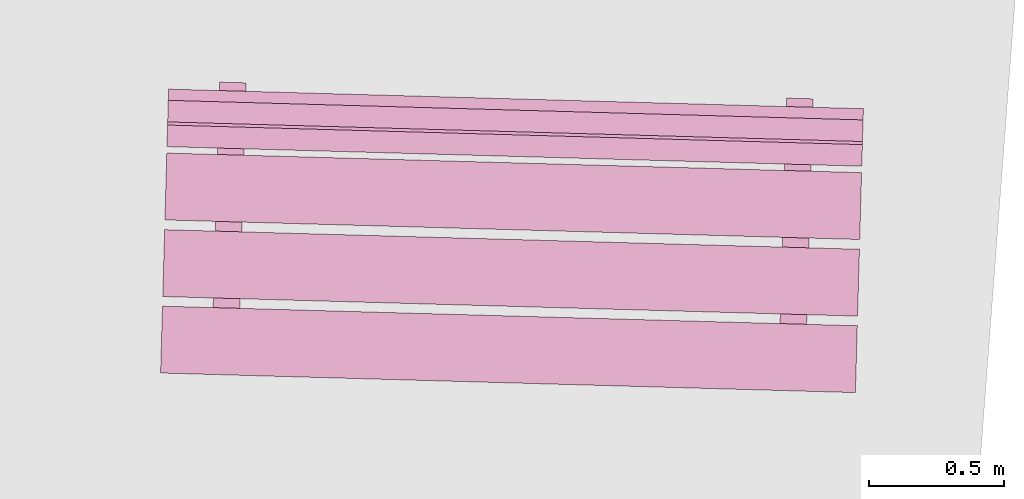
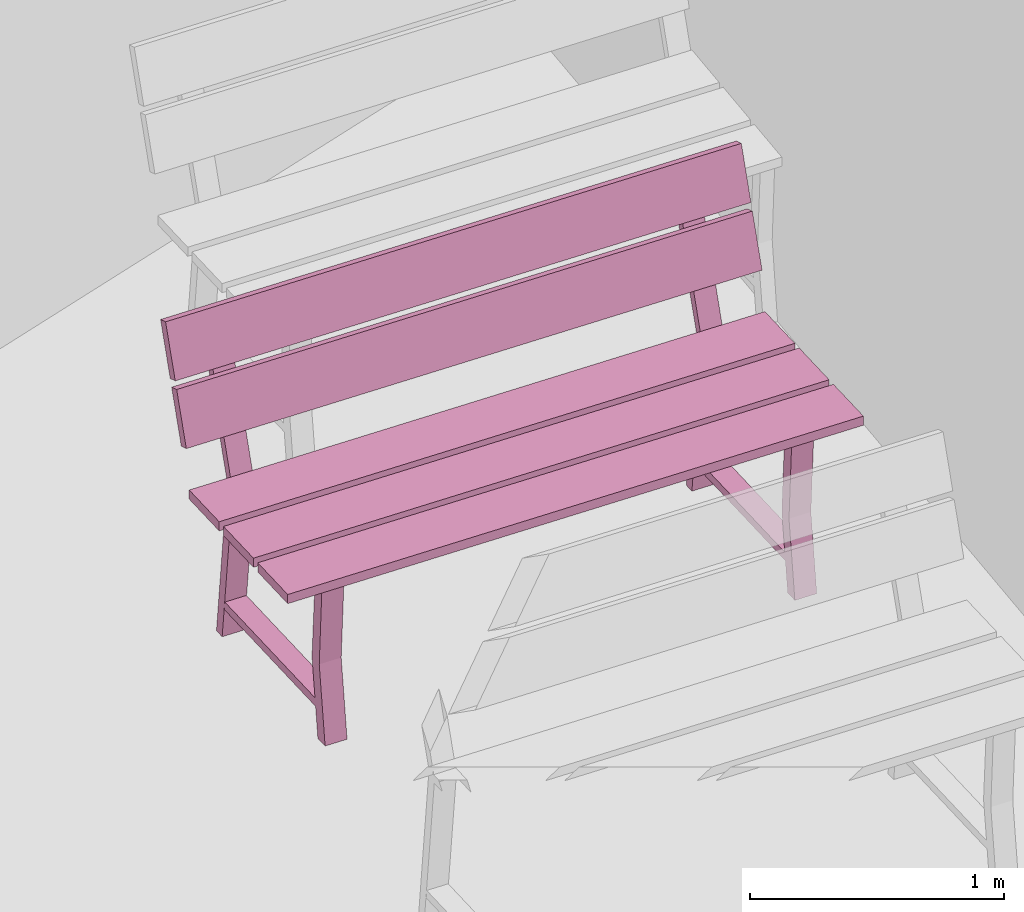
# One storey, part 19 of 200: 1 furnishing.
"""IFC4 building model written with IfcOpenShell, lengths in metres."""

from ifc_helpers import new_model, si_unit, origin_with_axes, place, context, subcontext, project, spatial, triangles, material, element, save


model = new_model("IFC4")

# Units and contexts
model_context = context("Model", 3, precision=1e-05, world=origin_with_axes())
body_context = subcontext(model_context, "Body", "Model", "MODEL_VIEW")
ifc_project = project(units=[si_unit("VOLUMEUNIT", "CUBIC_METRE"), si_unit("LENGTHUNIT", "METRE"), si_unit("AREAUNIT", "SQUARE_METRE")], contexts=[model_context])

# Site, building, storey
site_placement = place(None, origin_with_axes())
site = spatial("IfcSite", under=ifc_project, at=site_placement)
building_placement = place(site_placement, origin_with_axes())
building = spatial("IfcBuilding", under=site, at=building_placement, Name="Building")
storey_placement = place(building_placement, origin_with_axes())
storey = spatial("IfcBuildingStorey", under=building, at=storey_placement, Name="Ground")

# Furnishing
ifc_material = material(Name="bench")
furnishing_placement = place(storey_placement, origin_with_axes())
element("IfcFurnishingElement", 1, at=furnishing_placement, inside=storey, material=ifc_material, Name="cw_instances_bench_54", context=body_context, shape_type="Tessellation", body=[
    triangles([(238.3590412349621, -459.2790719184696, 0.8154595552323105), (238.36603468493595, -459.03091724197816, 0.8154595552323105), (235.7877960065481, -458.9582577883145, 0.8154595552323105), (235.78080255657426, -459.2064124648059, 0.8154595552323105), (235.96535536408615, -459.34840795630964, 0.3631407258093263), (236.0636534565917, -459.35117817528027, 0.3631407258093263), (236.06227739785223, -459.4000060660356, 1.4461350578594623e-07), (235.9639793053467, -459.39723584706496, 1.4461350578594623e-07), (236.0619650703966, -459.4110886531704, 0.3631407258093263), (235.96229544475085, -459.4569857391755, 1.606816730954958e-07), (236.0605935372564, -459.4597559581461, 1.606816730954958e-07), (235.96366697789108, -459.40831843419977, 0.3631407258093263), (236.08343428371427, -458.6492778580279, 0.7741643170422662), (236.08343428371427, -458.6492778580279, 0.7741643170422662), (236.08596459613344, -458.55949257863864, 0.0), (235.98766650362788, -458.5567223596681, 0.0), (235.98766650362788, -458.5567223596681, 0.0), (235.98465435356096, -458.6464940599963, 0.7741643170422662), (236.08223475955734, -458.69184161843526, 0.7346366254607741), (235.98634023689104, -458.6037834374265, 1.6068167309549576e-08), (236.0846383293966, -458.6065536563971, 1.6068167309549576e-08), (235.98393666705178, -458.68907139946464, 0.7352793682213234), (235.96467638976245, -459.37250059360287, 0.7352794646303272), (236.0629654292589, -459.3755920483799, 0.7346367218697779), (236.0612634644555, -459.435984347856, 0.7741644616557719), (235.96248353430215, -459.4332005498244, 0.7741644616557719), (238.35104290188468, -459.56288373734577, 0.8154596516413144), (238.35803635140587, -459.31472907691614, 0.8154595552323105), (235.77979767301804, -459.24206962325246, 0.8154595552323105), (235.77280422349682, -459.4902242836821, 0.8154596516413144), (238.36705314845844, -458.99477821376024, 0.8154595552323105), (238.37404659797966, -458.7466235533306, 0.8154594588233067), (235.7958079195918, -458.673964099667, 0.8154594588233067), (235.7888144700706, -458.9221187600966, 0.8154595552323105), (238.3747165211049, -458.7228520875966, 0.9999220838096051), (235.79873657029532, -458.57004423599363, 1.234838593466216), (235.79647784271702, -458.65019263393293, 0.9999220838096051), (238.37697524868315, -458.6427036896573, 1.234838593466216), (238.37730115746302, -458.63113918456577, 1.2690638219718915), (235.80132120574817, -458.4783313650864, 1.5039802352194984), (235.7990624790752, -458.5584797309021, 1.2690638219718915), (238.379559884136, -458.55099081875005, 1.5039802352194984), (235.99162045211648, -458.4107159494546, 1.4583467364693816), (236.08991864099278, -458.4134861711411, 1.4583467364693816), (236.08343428371427, -458.6492778580279, 0.7741643170422662), (235.98465435356096, -458.6464940599963, 0.7741643170422662), (235.9840543566226, -458.6848953179199, 0.7738429536960751), (236.08236602818914, -458.6871836992427, 0.7738429536960751), (236.08884585941573, -458.4515526141973, 1.4723259616878532), (235.99053409147845, -458.4492642301586, 1.4723259616878532), (235.79765020784671, -458.6085925809448, 0.9857820483726994), (235.79990440937308, -458.52860478484683, 1.2206986544383143), (238.37588888623455, -458.6812520346084, 0.9857820483726994), (238.37814308776095, -458.6012642385105, 1.2206986544383143), (235.8002348437522, -458.51687969397574, 1.2549238829439897), (235.80249357087783, -458.4367313120982, 1.4898404890096046), (238.37847352214004, -458.58953914763936, 1.2549238829439897), (238.38073224926566, -458.50939076576185, 1.4898404890096046), (238.06896805823652, -459.40769158678114, 0.3631407258093263), (238.16726615074208, -459.41046180575177, 0.3631407258093263), (238.1658900920026, -459.4592896965071, 1.4461350578594623e-07), (238.06759199949707, -459.45651947753646, 1.4461350578594623e-07), (238.165577764547, -459.4703722836419, 0.3631407258093263), (238.06590813890122, -459.516269369647, 1.606816730954958e-07), (238.16420623140678, -459.5190395886176, 1.606816730954958e-07), (238.06727967204145, -459.46760206467127, 0.3631407258093263), (238.18704697786464, -458.70856148849947, 0.7741643170422662), (238.18704697786464, -458.70856148849947, 0.7741643170422662), (238.1895772902838, -458.61877620911014, 0.0), (238.09127919777825, -458.61600599013957, 0.0), (238.09127919777825, -458.61600599013957, 0.0), (238.08842760136736, -458.7057822151618, 0.7741643170422662), (238.1858474537077, -458.75112524890676, 0.7346366254607741), (238.0899529310414, -458.663067067898, 1.6068167309549576e-08), (238.18825102354697, -458.6658372868686, 1.6068167309549576e-08), (238.08754936120218, -458.74835502993614, 0.7352793682213234), (238.06828908391282, -459.43178422407436, 0.7352794646303272), (238.16657812340927, -459.43487567885137, 0.7346367218697779), (238.16487615860586, -459.4952679783275, 0.7741644616557719), (238.06625678210855, -459.49248870498985, 0.7741644616557719), (238.09539379629362, -458.4700041073359, 1.4583467364693816), (238.19353135120494, -458.4727698020653, 1.4583467364693816), (238.18704697786464, -458.70856148849947, 0.7741643170422662), (238.08842760136736, -458.7057822151618, 0.7741643170422662), (238.08766705077298, -458.74417894839144, 0.7738429536960751), (238.1859787223395, -458.7464673297142, 0.7738429536960751), (238.1924585696279, -458.5108362451214, 1.4723259616878532), (238.0943074356556, -458.5085523880399, 1.4723259616878532), (238.36603468493595, -459.03091724197816, 0.8154595552323105), (235.7877960065481, -458.9582577883145, 0.7715934584772401), (235.7877960065481, -458.9582577883145, 0.8154595552323105), (238.36603468493595, -459.03091724197816, 0.7715934584772401), (238.3590412349621, -459.2790719184696, 0.771593506681742), (235.78080255657426, -459.2064124648059, 0.8154595552323105), (235.78080255657426, -459.2064124648059, 0.771593506681742), (238.3590412349621, -459.2790719184696, 0.8154595552323105), (235.9639793053467, -459.39723584706496, 1.4461350578594623e-07), (235.96366697789108, -459.40831843419977, 0.3631407258093263), (235.96535536408615, -459.34840795630964, 0.3631407258093263), (235.96229544475085, -459.4569857391755, 1.606816730954958e-07), (235.98393666705178, -458.68907139946464, 0.7352793682213234), (235.98465435356096, -458.6464940599963, 0.7741643170422662), (235.98766650362788, -458.5567223596681, 0.0), (235.98634023689104, -458.6037834374265, 1.6068167309549576e-08), (236.0619650703966, -459.4110886531704, 0.3631407258093263), (236.0636534565917, -459.35117817528027, 0.3631407258093263), (236.0629654292589, -459.3755920483799, 0.7346367218697779), (236.0612634644555, -459.435984347856, 0.7741644616557719), (236.08343428371427, -458.6492778580279, 0.7741643170422662), (236.08223475955734, -458.69184161843526, 0.7346366254607741), (236.08596459613344, -458.55949257863864, 0.0), (236.0846383293966, -458.6065536563971, 1.6068167309549576e-08), (235.96467638976245, -459.37250059360287, 0.7352794646303272), (235.96248353430215, -459.4332005498244, 0.7741644616557719), (236.06227739785223, -459.4000060660356, 1.4461350578594623e-07), (236.0605935372564, -459.4597559581461, 1.606816730954958e-07), (235.99162045211648, -458.4107159494546, 1.4583467364693816), (236.08884585941573, -458.4515526141973, 1.4723259616878532), (236.08991864099278, -458.4134861711411, 1.4583467364693816), (235.99053409147845, -458.4492642301586, 1.4723259616878532), (236.08319714966146, -458.6177651919651, 0.13995373726617685), (236.08319714966146, -458.6177651919651, 0.17948142884766885), (236.06138845121887, -459.3916222334761, 0.13995388187968263), (236.06137487125258, -459.39210410324745, 0.1794815734611746), (235.98682640774703, -458.6150492892384, 0.17948142884766885), (235.98714769173878, -458.6150583436054, 0.14059646395855885), (235.96534804585264, -459.38859416537184, 0.14059660857206463), (235.96500412933815, -459.3893882005207, 0.1794815734611746), (238.35803635140587, -459.31472907691614, 0.8154595552323105), (235.77979767301804, -459.24206962325246, 0.771593506681742), (235.77979767301804, -459.24206962325246, 0.8154595552323105), (238.35803635140587, -459.31472907691614, 0.771593506681742), (238.35104290188468, -459.56288373734577, 0.7715935548862439), (235.77280422349682, -459.4902242836821, 0.8154596516413144), (235.77280422349682, -459.4902242836821, 0.7715935548862439), (238.35104290188468, -459.56288373734577, 0.8154596516413144), (238.37404659797966, -458.7466235533306, 0.8154594588233067), (235.7958079195918, -458.673964099667, 0.7715934102727381), (235.7958079195918, -458.673964099667, 0.8154594588233067), (238.37404659797966, -458.7466235533306, 0.7715934102727381), (238.3670531480058, -458.99477822982203, 0.7715934584772401), (235.7888144700706, -458.9221187600966, 0.8154595552323105), (235.78881446961796, -458.9221187761584, 0.7715934584772401), (238.36705314845844, -458.99477821376024, 0.8154595552323105), (235.79990440937308, -458.52860478484683, 1.2206986544383143), (238.37697524868315, -458.6427036896573, 1.234838593466216), (238.37814308776095, -458.6012642385105, 1.2206986544383143), (235.79873657029532, -458.57004423599363, 1.234838593466216), (238.37588888623455, -458.6812520346084, 0.9857820483726994), (235.79647784271702, -458.65019263393293, 0.9999220838096051), (235.79765020784671, -458.6085925809448, 0.9857820483726994), (238.3747165211049, -458.7228520875966, 0.9999220838096051), (235.80249357087783, -458.4367313120982, 1.4898404890096046), (238.379559884136, -458.55099081875005, 1.5039802352194984), (238.38073224926566, -458.50939076576185, 1.4898404890096046), (235.80132120574817, -458.4783313650864, 1.5039802352194984), (238.37847352214004, -458.58953914763936, 1.2549238829439897), (235.7990624790752, -458.5584797309021, 1.2690638219718915), (235.8002348437522, -458.51687969397574, 1.2549238829439897), (238.37730115746302, -458.63113918456577, 1.2690638219718915), (238.06759199949707, -459.45651947753646, 1.4461350578594623e-07), (238.06727967204145, -459.46760206467127, 0.3631407258093263), (238.06896805823652, -459.40769158678114, 0.3631407258093263), (238.06590813890122, -459.516269369647, 1.606816730954958e-07), (238.08754936120218, -458.74835502993614, 0.7352793682213234), (238.08842760136736, -458.7057822151618, 0.7741643170422662), (238.09127919777825, -458.61600599013957, 0.0), (238.0899529310414, -458.663067067898, 1.6068167309549576e-08), (238.165577764547, -459.4703722836419, 0.3631407258093263), (238.16726615074208, -459.41046180575177, 0.3631407258093263), (238.16657812340927, -459.43487567885137, 0.7346367218697779), (238.16487615860586, -459.4952679783275, 0.7741644616557719), (238.18704697786464, -458.70856148849947, 0.7741643170422662), (238.1858474537077, -458.75112524890676, 0.7346366254607741), (238.1895772902838, -458.61877620911014, 0.0), (238.18825102354697, -458.6658372868686, 1.6068167309549576e-08), (238.06828908391282, -459.43178422407436, 0.7352794646303272), (238.06625678210855, -459.49248870498985, 0.7741644616557719), (238.1658900920026, -459.4592896965071, 1.4461350578594623e-07), (238.16420623140678, -459.5190395886176, 1.606816730954958e-07), (238.09539379629362, -458.4700041073359, 1.4583467364693816), (238.1924585696279, -458.5108362451214, 1.4723259616878532), (238.19353135120494, -458.4727698020653, 1.4583467364693816), (238.0943074356556, -458.5085523880399, 1.4723259616878532), (238.1869704938386, -458.6770533498464, 0.13995373726617685), (238.1869704938386, -458.6770533498464, 0.17948142884766885), (238.16516179539602, -459.4509103913574, 0.13995388187968263), (238.16514821542972, -459.4513922611288, 0.1794815734611746), (238.0904391018974, -458.6743329197099, 0.17948142884766885), (238.09092093954519, -458.6743464987709, 0.14059646395855885), (238.06912129365904, -459.4478823205373, 0.14059660857206463), (238.06861682348853, -459.4486718309923, 0.1794815734611746), (238.3590412349621, -459.2790719184696, 0.8154595552323105), (238.36603468493595, -459.03091724197816, 0.7715934584772401), (238.36603468493595, -459.03091724197816, 0.8154595552323105), (238.3590412349621, -459.2790719184696, 0.771593506681742), (235.7877960065481, -458.9582577883145, 0.8154595552323105), (235.7877960065481, -458.9582577883145, 0.7715934584772401), (235.78080255657426, -459.2064124648059, 0.771593506681742), (235.78080255657426, -459.2064124648059, 0.8154595552323105), (238.35104290188468, -459.56288373734577, 0.8154596516413144), (238.35803635140587, -459.31472907691614, 0.771593506681742), (238.35803635140587, -459.31472907691614, 0.8154595552323105), (238.35104290188468, -459.56288373734577, 0.7715935548862439), (235.77979767301804, -459.24206962325246, 0.8154595552323105), (235.77979767301804, -459.24206962325246, 0.771593506681742), (235.77280422349682, -459.4902242836821, 0.7715935548862439), (235.77280422349682, -459.4902242836821, 0.8154596516413144), (238.36705314845844, -458.99477821376024, 0.8154595552323105), (238.37404659797966, -458.7466235533306, 0.7715934102727381), (238.37404659797966, -458.7466235533306, 0.8154594588233067), (238.3670531480058, -458.99477822982203, 0.7715934584772401), (235.7958079195918, -458.673964099667, 0.8154594588233067), (235.7958079195918, -458.673964099667, 0.7715934102727381), (235.78881446961796, -458.9221187761584, 0.7715934584772401), (235.7888144700706, -458.9221187600966, 0.8154595552323105), (238.37588888623455, -458.6812520346084, 0.9857820483726994), (238.37814308776095, -458.6012642385105, 1.2206986544383143), (238.37697524868315, -458.6427036896573, 1.234838593466216), (238.3747165211049, -458.7228520875966, 0.9999220838096051), (235.79873657029532, -458.57004423599363, 1.234838593466216), (235.79765020784671, -458.6085925809448, 0.9857820483726994), (235.79647784271702, -458.65019263393293, 0.9999220838096051), (235.79990440937308, -458.52860478484683, 1.2206986544383143), (238.37847352214004, -458.58953914763936, 1.2549238829439897), (238.38073224926566, -458.50939076576185, 1.4898404890096046), (238.379559884136, -458.55099081875005, 1.5039802352194984), (238.37730115746302, -458.63113918456577, 1.2690638219718915), (235.80132120574817, -458.4783313650864, 1.5039802352194984), (235.8002348437522, -458.51687969397574, 1.2549238829439897), (235.7990624790752, -458.5584797309021, 1.2690638219718915), (235.80249357087783, -458.4367313120982, 1.4898404890096046), (236.08236602818914, -458.6871836992427, 0.7738429536960751), (236.08884585941573, -458.4515526141973, 1.4723259616878532), (236.08991864099278, -458.4134861711411, 1.4583467364693816), (235.98465435356096, -458.6464940599963, 0.7741643170422662), (235.9840543566226, -458.6848953179199, 0.7738429536960751), (235.99053409147845, -458.4492642301586, 1.4723259616878532), (235.99162045211648, -458.4107159494546, 1.4583467364693816), (238.1859787223395, -458.7464673297142, 0.7738429536960751), (238.1924585696279, -458.5108362451214, 1.4723259616878532), (238.19353135120494, -458.4727698020653, 1.4583467364693816), (238.08842760136736, -458.7057822151618, 0.7741643170422662), (238.08766705077298, -458.74417894839144, 0.7738429536960751), (238.0943074356556, -458.5085523880399, 1.4723259616878532), (238.09539379629362, -458.4700041073359, 1.4583467364693816), (236.08343428371427, -458.6492778580279, 0.7741643170422662), (235.98465435356096, -458.6464940599963, 0.7741643170422662), (236.0612634644555, -459.435984347856, 0.7741644616557719), (235.96248353430215, -459.4332005498244, 0.7741644616557719), (236.08319714966146, -458.6177651919651, 0.17948142884766885), (235.98682640774703, -458.6150492892384, 0.17948142884766885), (236.06137487125258, -459.39210410324745, 0.1794815734611746), (235.96500412933815, -459.3893882005207, 0.1794815734611746), (238.18704697786464, -458.70856148849947, 0.7741643170422662), (238.08842760136736, -458.7057822151618, 0.7741643170422662), (238.16487615860586, -459.4952679783275, 0.7741644616557719), (238.06625678210855, -459.49248870498985, 0.7741644616557719), (238.1869704938386, -458.6770533498464, 0.17948142884766885), (238.0904391018974, -458.6743329197099, 0.17948142884766885), (238.16514821542972, -459.4513922611288, 0.1794815734611746), (238.06861682348853, -459.4486718309923, 0.1794815734611746)], [[1, 2, 3], [3, 4, 1], [5, 6, 7], [7, 8, 5], [9, 10, 11], [10, 9, 12], [14, 15, 16], [17, 18, 13], [19, 20, 21], [20, 19, 22], [23, 24, 5], [24, 6, 5], [12, 9, 25], [25, 26, 12], [27, 28, 29], [29, 30, 27], [31, 32, 33], [33, 34, 31], [35, 36, 37], [35, 38, 36], [39, 40, 41], [39, 42, 40], [43, 44, 45], [45, 46, 43], [47, 48, 49], [49, 50, 47], [51, 52, 53], [54, 53, 52], [55, 56, 57], [58, 57, 56], [59, 60, 61], [61, 62, 59], [63, 64, 65], [64, 63, 66], [68, 69, 71], [70, 72, 67], [73, 74, 75], [74, 73, 76], [77, 78, 59], [78, 60, 59], [66, 63, 79], [79, 80, 66], [81, 82, 83], [83, 84, 81], [85, 86, 87], [87, 88, 85], [89, 90, 91], [89, 92, 90], [93, 94, 95], [93, 96, 94], [97, 98, 99], [97, 100, 98], [101, 102, 103], [103, 104, 101], [105, 106, 107], [107, 108, 105], [109, 110, 111], [110, 112, 111], [108, 107, 109], [107, 110, 109], [113, 99, 98], [98, 114, 113], [115, 106, 105], [105, 116, 115], [117, 118, 119], [117, 120, 118], [102, 101, 113], [113, 114, 102], [121, 122, 123], [122, 124, 123], [125, 126, 127], [127, 128, 125], [129, 130, 131], [129, 132, 130], [133, 134, 135], [133, 136, 134], [137, 138, 139], [137, 140, 138], [141, 142, 143], [141, 144, 142], [145, 146, 147], [145, 148, 146], [149, 150, 151], [149, 152, 150], [153, 154, 155], [153, 156, 154], [157, 158, 159], [157, 160, 158], [161, 162, 163], [161, 164, 162], [165, 166, 167], [167, 168, 165], [169, 170, 171], [171, 172, 169], [173, 174, 175], [174, 176, 175], [172, 171, 173], [171, 174, 173], [177, 163, 162], [162, 178, 177], [179, 170, 169], [169, 180, 179], [181, 182, 183], [181, 184, 182], [166, 165, 177], [177, 178, 166], [185, 186, 187], [186, 188, 187], [189, 190, 191], [191, 192, 189], [193, 194, 195], [194, 193, 196], [197, 198, 199], [199, 200, 197], [201, 202, 203], [202, 201, 204], [205, 206, 207], [207, 208, 205], [209, 210, 211], [210, 209, 212], [213, 214, 215], [215, 216, 213], [217, 218, 219], [219, 220, 217], [221, 222, 223], [222, 221, 224], [225, 226, 227], [227, 228, 225], [229, 230, 231], [230, 229, 232], [233, 109, 234], [109, 235, 234], [236, 237, 238], [238, 239, 236], [240, 173, 241], [173, 242, 241], [243, 244, 245], [245, 246, 243], [247, 248, 249], [248, 250, 249], [251, 252, 253], [252, 254, 253], [255, 256, 257], [256, 258, 257], [259, 260, 261], [260, 262, 261]], closed=True),
])

save(model, "model.ifc")
